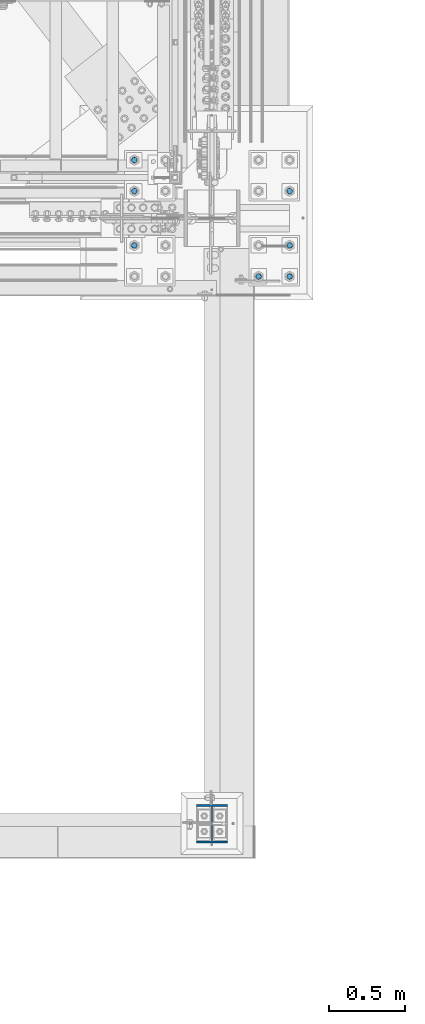
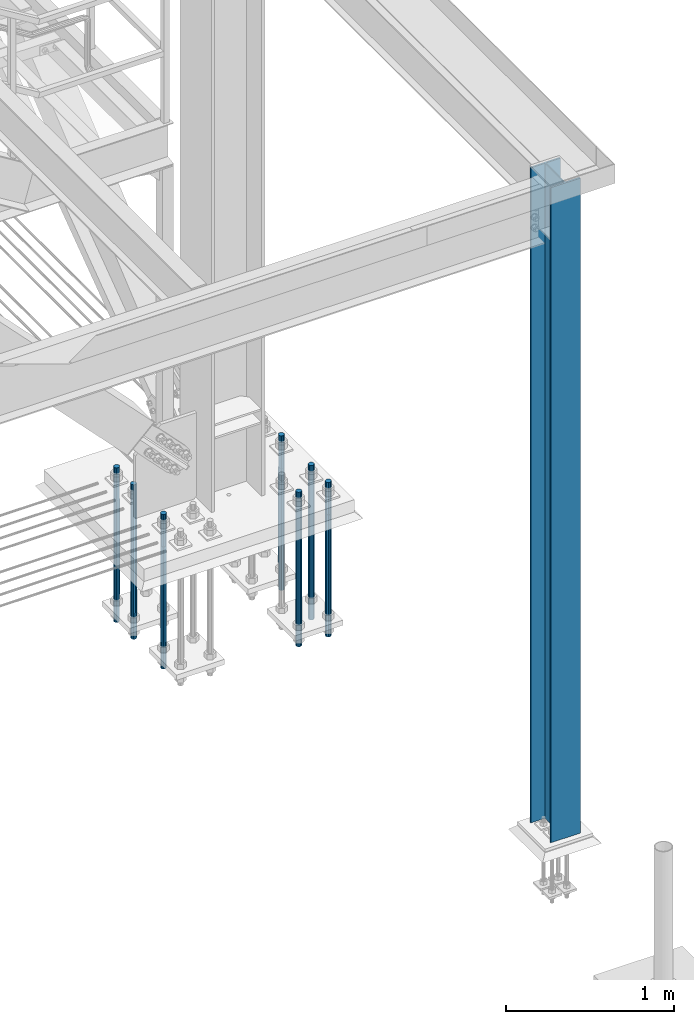
# One storey, part 1408 of 3843: 8 columns, 2 elements without a shape of their own.
"""IFC2X3 building model written with IfcOpenShell, lengths in millimetres."""

from ifc_helpers import new_model, si_unit, frame, origin_with_axes, place, context, subcontext, project, spatial, faceted_brep, material, type_object, element, aggregate, save


model = new_model("IFC2X3")

# Units and contexts
model_context = context("Model", 3, precision=1e-05, world=origin_with_axes())
body_context = subcontext(model_context, "Body", "Model", "MODEL_VIEW")
ifc_project = project(units=[si_unit("LENGTHUNIT", "METRE", prefix="MILLI"), si_unit("AREAUNIT", "SQUARE_METRE"), si_unit("VOLUMEUNIT", "CUBIC_METRE"), si_unit("MASSUNIT", "GRAM", prefix="KILO"), si_unit("TIMEUNIT", "SECOND"), si_unit("PLANEANGLEUNIT", "RADIAN"), si_unit("SOLIDANGLEUNIT", "STERADIAN"), si_unit("THERMODYNAMICTEMPERATUREUNIT", "DEGREE_CELSIUS"), si_unit("LUMINOUSINTENSITYUNIT", "LUMEN")], contexts=[model_context])

# Site, building, storey
site_placement = place(None, origin_with_axes())
site = spatial("IfcSite", under=ifc_project, at=site_placement, CompositionType="ELEMENT")
building_placement = place(site_placement, origin_with_axes())
building = spatial("IfcBuilding", under=site, at=building_placement, Name="Undefined", CompositionType="ELEMENT")
storey_placement = place(building_placement, origin_with_axes())
storey = spatial("IfcBuildingStorey", under=building, at=storey_placement, Name="Undefined", CompositionType="ELEMENT", Elevation=0.0)

# Assembly, column
assembly_1_placement = place(storey_placement, origin_with_axes())
assembly_1 = element("IfcElementAssembly", 1, at=assembly_1_placement, inside=storey, Name="COLUMN", AssemblyPlace="NOTDEFINED", PredefinedType="RIGID_FRAME")
ifc_material_1 = material(Name="STEEL/A992")
column_type_1 = type_object("IfcColumnType", Name="W10X39", PredefinedType="NOTDEFINED")
column_1_placement = place(assembly_1_placement, frame((85648.8, 11036.3, 30022.8), z_axis=(0.0, 1.0, 0.0), x_axis=(0.0, 0.0, 1.0)))
column_1 = element("IfcColumn", 2, at=column_1_placement, type_object=column_type_1, material=ifc_material_1, Name="COLUMN", ObjectType="W10X39", context=body_context, shape_type="Brep", body=[
    faceted_brep([(63.4999999999964, 101.600000000006, -125.4125), (63.4999999999964, 101.600000000006, -112.7125), (4826.00000000001, 101.600000000006, -112.7125), (4826.00000000001, 101.600000000006, -125.4125), (63.4999999999964, 3.96875, -112.7125), (4826.00000000001, 3.96875, -112.7125), (63.4999999999964, 3.96875, 112.7125), (4826.00000000001, 3.96875, 112.7125), (63.4999999999964, 101.600000000006, 112.7125), (4826.00000000001, 101.600000000006, 112.7125), (63.4999999999964, 101.600000000006, 125.4125), (4826.00000000001, 101.600000000006, 125.4125), (63.4999999999964, -101.600000000006, 125.4125), (4826.00000000001, -101.600000000006, 125.4125), (63.4999999999964, -101.600000000006, 112.7125), (4826.00000000001, -101.600000000006, 112.7125), (63.4999999999964, -3.96875, 112.7125), (4826.00000000001, -3.96875, 112.7125), (63.4999999999964, -3.96875, -112.7125), (4826.00000000001, -3.96875, -112.7125), (63.4999999999964, -101.600000000006, -112.7125), (4826.00000000001, -101.600000000006, -112.7125), (63.4999999999964, -101.600000000006, -125.4125), (4826.00000000001, -101.600000000006, -125.4125)], [[[0, 1, 2, 3]], [[1, 4, 5, 2]], [[4, 6, 7, 5]], [[6, 8, 9, 7]], [[8, 10, 11, 9]], [[10, 12, 13, 11]], [[12, 14, 15, 13]], [[14, 16, 17, 15]], [[16, 18, 19, 17]], [[18, 20, 21, 19]], [[20, 22, 23, 21]], [[22, 0, 3, 23]], [[5, 7, 9, 11, 13, 15, 17, 19, 21, 23, 3, 2]], [[22, 20, 18, 16, 14, 12, 10, 8, 6, 4, 1, 0]]]),
])
aggregate(assembly_1, [column_1])

# Assembly, columns
assembly_2_placement = place(storey_placement, origin_with_axes())
assembly_2 = element("IfcElementAssembly", 3, at=assembly_2_placement, inside=storey, Name="TEMPLATE", AssemblyPlace="NOTDEFINED", PredefinedType="RIGID_FRAME")
ifc_material_2 = material(Name="Undefined/F1554-GR.55")
column_type_2 = type_object("IfcColumnType", PredefinedType="NOTDEFINED")
column_2_placement = place(assembly_2_placement, frame((86156.8, 14617.7, 30022.8), z_axis=(1.0, 0.0, 0.0), x_axis=(0.0, 0.0, -1.0)))
column_2 = element("IfcColumn", 4, at=column_2_placement, type_object=column_type_2, material=ifc_material_2, Name="ANCHOR_ROD", context=body_context, shape_type="Brep", body=[
    faceted_brep([(-234.950000000001, -16.0214699700155, 9.25), (-234.950000000001, -9.25, 16.0214699700155), (-234.950000000001, 0.0, 18.5), (-234.950000000001, 9.25, 16.0214699700155), (-234.950000000001, 16.0214699700155, 9.25), (-234.950000000001, 18.5, 0.0), (-234.950000000001, 16.0214699700155, -9.25), (-234.950000000001, 9.25, -16.0214699700155), (-234.950000000001, 0.0, -18.5), (-234.950000000001, -9.25, -16.0214699700155), (-234.950000000001, -16.0214699700155, -9.25), (-234.950000000001, -18.5, 0.0), (0.0, 18.5, 0.0), (0.0, 16.0214699700118, -9.25), (0.0, 9.25, -16.0214699700155), (0.0, 0.0, -18.5), (0.0, -9.25, -16.0214699700155), (0.0, -16.0214699700118, -9.25), (0.0, -18.5, 0.0), (0.0, -16.0214699700118, 9.25), (0.0, -9.25, 16.0214699700155), (0.0, 0.0, 18.5), (0.0, 9.25, 16.0214699700155), (0.0, 16.0214699700118, 9.25), (0.0, -16.4977839420972, 9.52500000000146), (0.0, -9.52500000000146, 16.4977839420972), (0.0, 0.0, 19.0499989999989), (0.0, 9.52500000000146, 16.4977839420972), (0.0, 16.4977839420972, 9.52500000000146), (0.0, 19.0500000000029, 0.0), (0.0, 16.4977839420972, -9.52500000000146), (0.0, 9.52500000000146, -16.4977839420972), (0.0, 0.0, -19.0499989999989), (0.0, -9.52500000000146, -16.4977839420972), (0.0, -16.4977839420972, -9.52500000000146), (0.0, -19.0500000000029, 0.0), (698.5, -19.0499999999993, 0.0), (698.5, -16.4977839420935, 9.52499999999418), (698.5, -9.52500000000146, 16.4977839420899), (698.5, 0.0, 19.0500000000029), (698.5, 9.52500000000146, 16.4977839420899), (698.5, 16.4977839420935, 9.52499999999418), (698.5, 19.0499999999993, 0.0), (698.5, 16.4977839420935, -9.52499999999418), (698.5, 9.52500000000146, -16.4977839420899), (698.5, 0.0, -19.0500000000029), (698.5, -9.52500000000146, -16.4977839420899), (698.5, -16.4977839420935, -9.52499999999418), (698.5, -9.25, 16.0214699700155), (698.5, 0.0, 18.5), (698.5, 9.25, 16.0214699700155), (698.5, 16.0214699700118, 9.25), (698.5, 18.5, 0.0), (698.5, 16.0214699700118, -9.25), (698.5, 9.25, -16.0214699700155), (698.5, 0.0, -18.5), (698.5, -9.25, -16.0214699700155), (698.5, -16.0214699700118, -9.25), (698.5, -18.5, 0.0), (698.5, -16.0214699700118, 9.25), (889.0, -9.25, -16.0214699700155), (889.0, 0.0, -18.5), (889.0, 9.25, -16.0214699700155), (889.0, 16.0214699700118, -9.25), (889.0, 18.5, 0.0), (889.0, 16.0214699700118, 9.25), (889.0, 9.25, 16.0214699700155), (889.0, 0.0, 18.5), (889.0, -9.25, 16.0214699700155), (889.0, -16.0214699700118, 9.25), (889.0, -18.5, 0.0), (889.0, -16.0214699700118, -9.25)], [[[0, 1, 2, 3, 4, 5, 6, 7, 8, 9, 10, 11]], [[6, 5, 12, 13]], [[7, 6, 13, 14]], [[8, 7, 14, 15]], [[9, 8, 15, 16]], [[10, 9, 16, 17]], [[11, 10, 17, 18]], [[0, 11, 18, 19]], [[1, 0, 19, 20]], [[2, 1, 20, 21]], [[3, 2, 21, 22]], [[4, 3, 22, 23]], [[5, 4, 23, 12]], [[24, 25, 26, 27, 28, 29, 30, 31, 32, 33, 34, 35], [22, 21, 20, 19, 18, 17, 16, 15, 14, 13, 12, 23]], [[24, 35, 36, 37]], [[25, 24, 37, 38]], [[26, 25, 38, 39]], [[27, 26, 39, 40]], [[28, 27, 40, 41]], [[29, 28, 41, 42]], [[30, 29, 42, 43]], [[31, 30, 43, 44]], [[32, 31, 44, 45]], [[33, 32, 45, 46]], [[34, 33, 46, 47]], [[35, 34, 47, 36]], [[46, 45, 44, 43, 42, 41, 40, 39, 38, 37, 36, 47], [48, 49, 50, 51, 52, 53, 54, 55, 56, 57, 58, 59]], [[60, 61, 62, 63, 64, 65, 66, 67, 68, 69, 70, 71]], [[68, 67, 49, 48]], [[69, 68, 48, 59]], [[70, 69, 59, 58]], [[71, 70, 58, 57]], [[60, 71, 57, 56]], [[61, 60, 56, 55]], [[62, 61, 55, 54]], [[63, 62, 54, 53]], [[64, 63, 53, 52]], [[65, 64, 52, 51]], [[66, 65, 51, 50]], [[67, 66, 50, 49]]]),
])
column_3_placement = place(assembly_2_placement, frame((86156.8, 14820.9, 30022.8), z_axis=(1.0, 0.0, 0.0), x_axis=(0.0, 0.0, -1.0)))
column_3 = element("IfcColumn", 5, at=column_3_placement, type_object=column_type_2, material=ifc_material_2, Name="ANCHOR_ROD", context=body_context, shape_type="Brep", body=[
    faceted_brep([(-234.950000000001, -16.0214699700155, 9.25), (-234.950000000001, -9.25, 16.0214699700155), (-234.950000000001, 0.0, 18.5), (-234.950000000001, 9.25, 16.0214699700155), (-234.950000000001, 16.0214699700155, 9.25), (-234.950000000001, 18.5, 0.0), (-234.950000000001, 16.0214699700155, -9.25), (-234.950000000001, 9.25, -16.0214699700155), (-234.950000000001, 0.0, -18.5), (-234.950000000001, -9.25, -16.0214699700155), (-234.950000000001, -16.0214699700155, -9.25), (-234.950000000001, -18.5, 0.0), (0.0, 18.5, 0.0), (0.0, 16.0214699700118, -9.25), (0.0, 9.25, -16.0214699700155), (0.0, 0.0, -18.5), (0.0, -9.25, -16.0214699700155), (0.0, -16.0214699700118, -9.25), (0.0, -18.5, 0.0), (0.0, -16.0214699700118, 9.25), (0.0, -9.25, 16.0214699700155), (0.0, 0.0, 18.5), (0.0, 9.25, 16.0214699700155), (0.0, 16.0214699700118, 9.25), (0.0, -16.4977839420972, 9.52500000000146), (0.0, -9.52500000000146, 16.4977839420972), (0.0, 0.0, 19.0499989999989), (0.0, 9.52500000000146, 16.4977839420972), (0.0, 16.4977839420972, 9.52500000000146), (0.0, 19.0500000000029, 0.0), (0.0, 16.4977839420972, -9.52500000000146), (0.0, 9.52500000000146, -16.4977839420972), (0.0, 0.0, -19.0499989999989), (0.0, -9.52500000000146, -16.4977839420972), (0.0, -16.4977839420972, -9.52500000000146), (0.0, -19.0500000000029, 0.0), (698.5, -19.0499999999993, 0.0), (698.5, -16.4977839420935, 9.52499999999418), (698.5, -9.52500000000146, 16.4977839420899), (698.5, 0.0, 19.0500000000029), (698.5, 9.52500000000146, 16.4977839420899), (698.5, 16.4977839420935, 9.52499999999418), (698.5, 19.0499999999993, 0.0), (698.5, 16.4977839420935, -9.52499999999418), (698.5, 9.52500000000146, -16.4977839420899), (698.5, 0.0, -19.0500000000029), (698.5, -9.52500000000146, -16.4977839420899), (698.5, -16.4977839420935, -9.52499999999418), (698.5, -9.25, 16.0214699700155), (698.5, 0.0, 18.5), (698.5, 9.25, 16.0214699700155), (698.5, 16.0214699700118, 9.25), (698.5, 18.5, 0.0), (698.5, 16.0214699700118, -9.25), (698.5, 9.25, -16.0214699700155), (698.5, 0.0, -18.5), (698.5, -9.25, -16.0214699700155), (698.5, -16.0214699700118, -9.25), (698.5, -18.5, 0.0), (698.5, -16.0214699700118, 9.25), (889.0, -9.25, -16.0214699700155), (889.0, 0.0, -18.5), (889.0, 9.25, -16.0214699700155), (889.0, 16.0214699700118, -9.25), (889.0, 18.5, 0.0), (889.0, 16.0214699700118, 9.25), (889.0, 9.25, 16.0214699700155), (889.0, 0.0, 18.5), (889.0, -9.25, 16.0214699700155), (889.0, -16.0214699700118, 9.25), (889.0, -18.5, 0.0), (889.0, -16.0214699700118, -9.25)], [[[0, 1, 2, 3, 4, 5, 6, 7, 8, 9, 10, 11]], [[6, 5, 12, 13]], [[7, 6, 13, 14]], [[8, 7, 14, 15]], [[9, 8, 15, 16]], [[10, 9, 16, 17]], [[11, 10, 17, 18]], [[0, 11, 18, 19]], [[1, 0, 19, 20]], [[2, 1, 20, 21]], [[3, 2, 21, 22]], [[4, 3, 22, 23]], [[5, 4, 23, 12]], [[24, 25, 26, 27, 28, 29, 30, 31, 32, 33, 34, 35], [22, 21, 20, 19, 18, 17, 16, 15, 14, 13, 12, 23]], [[24, 35, 36, 37]], [[25, 24, 37, 38]], [[26, 25, 38, 39]], [[27, 26, 39, 40]], [[28, 27, 40, 41]], [[29, 28, 41, 42]], [[30, 29, 42, 43]], [[31, 30, 43, 44]], [[32, 31, 44, 45]], [[33, 32, 45, 46]], [[34, 33, 46, 47]], [[35, 34, 47, 36]], [[46, 45, 44, 43, 42, 41, 40, 39, 38, 37, 36, 47], [48, 49, 50, 51, 52, 53, 54, 55, 56, 57, 58, 59]], [[60, 61, 62, 63, 64, 65, 66, 67, 68, 69, 70, 71]], [[68, 67, 49, 48]], [[69, 68, 48, 59]], [[70, 69, 59, 58]], [[71, 70, 58, 57]], [[60, 71, 57, 56]], [[61, 60, 56, 55]], [[62, 61, 55, 54]], [[63, 62, 54, 53]], [[64, 63, 53, 52]], [[65, 64, 52, 51]], [[66, 65, 51, 50]], [[67, 66, 50, 49]]]),
])
column_4_placement = place(assembly_2_placement, frame((86156.8, 15176.5, 30022.8), z_axis=(-1.0, 0.0, 0.0), x_axis=(0.0, 0.0, -1.0)))
column_4 = element("IfcColumn", 6, at=column_4_placement, type_object=column_type_2, material=ifc_material_2, Name="ANCHOR_ROD", context=body_context, shape_type="Brep", body=[
    faceted_brep([(-234.950000000001, -16.0214699700155, 9.25), (-234.950000000001, -9.25, 16.0214699700155), (-234.950000000001, 0.0, 18.5), (-234.950000000001, 9.25, 16.0214699700155), (-234.950000000001, 16.0214699700155, 9.25), (-234.950000000001, 18.5, 0.0), (-234.950000000001, 16.0214699700155, -9.25), (-234.950000000001, 9.25, -16.0214699700155), (-234.950000000001, 0.0, -18.5), (-234.950000000001, -9.25, -16.0214699700155), (-234.950000000001, -16.0214699700155, -9.25), (-234.950000000001, -18.5, 0.0), (0.0, 18.5, 0.0), (0.0, 16.0214699700118, -9.25), (0.0, 9.25, -16.0214699700155), (0.0, 0.0, -18.5), (0.0, -9.25, -16.0214699700155), (0.0, -16.0214699700118, -9.25), (0.0, -18.5, 0.0), (0.0, -16.0214699700118, 9.25), (0.0, -9.25, 16.0214699700155), (0.0, 0.0, 18.5), (0.0, 9.25, 16.0214699700155), (0.0, 16.0214699700118, 9.25), (0.0, -16.4977839420972, 9.52500000000146), (0.0, -9.52500000000146, 16.4977839420972), (0.0, 0.0, 19.0499989999989), (0.0, 9.52500000000146, 16.4977839420972), (0.0, 16.4977839420972, 9.52500000000146), (0.0, 19.0500000000029, 0.0), (0.0, 16.4977839420972, -9.52500000000146), (0.0, 9.52500000000146, -16.4977839420972), (0.0, 0.0, -19.0499989999989), (0.0, -9.52500000000146, -16.4977839420972), (0.0, -16.4977839420972, -9.52500000000146), (0.0, -19.0500000000029, 0.0), (698.5, -19.0499999999993, 0.0), (698.5, -16.4977839420935, 9.52499999999418), (698.5, -9.52500000000146, 16.4977839420899), (698.5, 0.0, 19.0500000000029), (698.5, 9.52500000000146, 16.4977839420899), (698.5, 16.4977839420935, 9.52499999999418), (698.5, 19.0499999999993, 0.0), (698.5, 16.4977839420935, -9.52499999999418), (698.5, 9.52500000000146, -16.4977839420899), (698.5, 0.0, -19.0500000000029), (698.5, -9.52500000000146, -16.4977839420899), (698.5, -16.4977839420935, -9.52499999999418), (698.5, -9.25, 16.0214699700155), (698.5, 0.0, 18.5), (698.5, 9.25, 16.0214699700155), (698.5, 16.0214699700118, 9.25), (698.5, 18.5, 0.0), (698.5, 16.0214699700118, -9.25), (698.5, 9.25, -16.0214699700155), (698.5, 0.0, -18.5), (698.5, -9.25, -16.0214699700155), (698.5, -16.0214699700118, -9.25), (698.5, -18.5, 0.0), (698.5, -16.0214699700118, 9.25), (889.0, -9.25, -16.0214699700155), (889.0, 0.0, -18.5), (889.0, 9.25, -16.0214699700155), (889.0, 16.0214699700118, -9.25), (889.0, 18.5, 0.0), (889.0, 16.0214699700118, 9.25), (889.0, 9.25, 16.0214699700155), (889.0, 0.0, 18.5), (889.0, -9.25, 16.0214699700155), (889.0, -16.0214699700118, 9.25), (889.0, -18.5, 0.0), (889.0, -16.0214699700118, -9.25)], [[[0, 1, 2, 3, 4, 5, 6, 7, 8, 9, 10, 11]], [[6, 5, 12, 13]], [[7, 6, 13, 14]], [[8, 7, 14, 15]], [[9, 8, 15, 16]], [[10, 9, 16, 17]], [[11, 10, 17, 18]], [[0, 11, 18, 19]], [[1, 0, 19, 20]], [[2, 1, 20, 21]], [[3, 2, 21, 22]], [[4, 3, 22, 23]], [[5, 4, 23, 12]], [[24, 25, 26, 27, 28, 29, 30, 31, 32, 33, 34, 35], [22, 21, 20, 19, 18, 17, 16, 15, 14, 13, 12, 23]], [[24, 35, 36, 37]], [[25, 24, 37, 38]], [[26, 25, 38, 39]], [[27, 26, 39, 40]], [[28, 27, 40, 41]], [[29, 28, 41, 42]], [[30, 29, 42, 43]], [[31, 30, 43, 44]], [[32, 31, 44, 45]], [[33, 32, 45, 46]], [[34, 33, 46, 47]], [[35, 34, 47, 36]], [[46, 45, 44, 43, 42, 41, 40, 39, 38, 37, 36, 47], [48, 49, 50, 51, 52, 53, 54, 55, 56, 57, 58, 59]], [[60, 61, 62, 63, 64, 65, 66, 67, 68, 69, 70, 71]], [[68, 67, 49, 48]], [[69, 68, 48, 59]], [[70, 69, 59, 58]], [[71, 70, 58, 57]], [[60, 71, 57, 56]], [[61, 60, 56, 55]], [[62, 61, 55, 54]], [[63, 62, 54, 53]], [[64, 63, 53, 52]], [[65, 64, 52, 51]], [[66, 65, 51, 50]], [[67, 66, 50, 49]]]),
])
column_5_placement = place(assembly_2_placement, frame((85953.6, 14617.7, 30022.8), z_axis=(1.0, 0.0, 0.0), x_axis=(0.0, 0.0, -1.0)))
column_5 = element("IfcColumn", 7, at=column_5_placement, type_object=column_type_2, material=ifc_material_2, Name="ANCHOR_ROD", context=body_context, shape_type="Brep", body=[
    faceted_brep([(-234.950000000001, -16.0214699700155, 9.25), (-234.950000000001, -9.25, 16.0214699700155), (-234.950000000001, 0.0, 18.5), (-234.950000000001, 9.25, 16.0214699700155), (-234.950000000001, 16.0214699700155, 9.25), (-234.950000000001, 18.5, 0.0), (-234.950000000001, 16.0214699700155, -9.25), (-234.950000000001, 9.25, -16.0214699700155), (-234.950000000001, 0.0, -18.5), (-234.950000000001, -9.25, -16.0214699700155), (-234.950000000001, -16.0214699700155, -9.25), (-234.950000000001, -18.5, 0.0), (0.0, 18.5, 0.0), (0.0, 16.0214699700118, -9.25), (0.0, 9.25, -16.0214699700155), (0.0, 0.0, -18.5), (0.0, -9.25, -16.0214699700155), (0.0, -16.0214699700118, -9.25), (0.0, -18.5, 0.0), (0.0, -16.0214699700118, 9.25), (0.0, -9.25, 16.0214699700155), (0.0, 0.0, 18.5), (0.0, 9.25, 16.0214699700155), (0.0, 16.0214699700118, 9.25), (0.0, -16.4977839420972, 9.52500000000146), (0.0, -9.52500000000146, 16.4977839420972), (0.0, 0.0, 19.0499989999989), (0.0, 9.52500000000146, 16.4977839420972), (0.0, 16.4977839420972, 9.52500000000146), (0.0, 19.0500000000029, 0.0), (0.0, 16.4977839420972, -9.52500000000146), (0.0, 9.52500000000146, -16.4977839420972), (0.0, 0.0, -19.0499989999989), (0.0, -9.52500000000146, -16.4977839420972), (0.0, -16.4977839420972, -9.52500000000146), (0.0, -19.0500000000029, 0.0), (698.5, -19.0499999999993, 0.0), (698.5, -16.4977839420935, 9.52499999999418), (698.5, -9.52500000000146, 16.4977839420899), (698.5, 0.0, 19.0500000000029), (698.5, 9.52500000000146, 16.4977839420899), (698.5, 16.4977839420935, 9.52499999999418), (698.5, 19.0499999999993, 0.0), (698.5, 16.4977839420935, -9.52499999999418), (698.5, 9.52500000000146, -16.4977839420899), (698.5, 0.0, -19.0500000000029), (698.5, -9.52500000000146, -16.4977839420899), (698.5, -16.4977839420935, -9.52499999999418), (698.5, -9.25, 16.0214699700155), (698.5, 0.0, 18.5), (698.5, 9.25, 16.0214699700155), (698.5, 16.0214699700118, 9.25), (698.5, 18.5, 0.0), (698.5, 16.0214699700118, -9.25), (698.5, 9.25, -16.0214699700155), (698.5, 0.0, -18.5), (698.5, -9.25, -16.0214699700155), (698.5, -16.0214699700118, -9.25), (698.5, -18.5, 0.0), (698.5, -16.0214699700118, 9.25), (889.0, -9.25, -16.0214699700155), (889.0, 0.0, -18.5), (889.0, 9.25, -16.0214699700155), (889.0, 16.0214699700118, -9.25), (889.0, 18.5, 0.0), (889.0, 16.0214699700118, 9.25), (889.0, 9.25, 16.0214699700155), (889.0, 0.0, 18.5), (889.0, -9.25, 16.0214699700155), (889.0, -16.0214699700118, 9.25), (889.0, -18.5, 0.0), (889.0, -16.0214699700118, -9.25)], [[[0, 1, 2, 3, 4, 5, 6, 7, 8, 9, 10, 11]], [[6, 5, 12, 13]], [[7, 6, 13, 14]], [[8, 7, 14, 15]], [[9, 8, 15, 16]], [[10, 9, 16, 17]], [[11, 10, 17, 18]], [[0, 11, 18, 19]], [[1, 0, 19, 20]], [[2, 1, 20, 21]], [[3, 2, 21, 22]], [[4, 3, 22, 23]], [[5, 4, 23, 12]], [[24, 25, 26, 27, 28, 29, 30, 31, 32, 33, 34, 35], [22, 21, 20, 19, 18, 17, 16, 15, 14, 13, 12, 23]], [[24, 35, 36, 37]], [[25, 24, 37, 38]], [[26, 25, 38, 39]], [[27, 26, 39, 40]], [[28, 27, 40, 41]], [[29, 28, 41, 42]], [[30, 29, 42, 43]], [[31, 30, 43, 44]], [[32, 31, 44, 45]], [[33, 32, 45, 46]], [[34, 33, 46, 47]], [[35, 34, 47, 36]], [[46, 45, 44, 43, 42, 41, 40, 39, 38, 37, 36, 47], [48, 49, 50, 51, 52, 53, 54, 55, 56, 57, 58, 59]], [[60, 61, 62, 63, 64, 65, 66, 67, 68, 69, 70, 71]], [[68, 67, 49, 48]], [[69, 68, 48, 59]], [[70, 69, 59, 58]], [[71, 70, 58, 57]], [[60, 71, 57, 56]], [[61, 60, 56, 55]], [[62, 61, 55, 54]], [[63, 62, 54, 53]], [[64, 63, 53, 52]], [[65, 64, 52, 51]], [[66, 65, 51, 50]], [[67, 66, 50, 49]]]),
])
column_6_placement = place(assembly_2_placement, frame((85140.8, 14820.9, 30022.8), z_axis=(1.0, 0.0, 0.0), x_axis=(0.0, 0.0, -1.0)))
column_6 = element("IfcColumn", 8, at=column_6_placement, type_object=column_type_2, material=ifc_material_2, Name="ANCHOR_ROD", context=body_context, shape_type="Brep", body=[
    faceted_brep([(-234.950000000001, -16.0214699700155, 9.25), (-234.950000000001, -9.25, 16.0214699700155), (-234.950000000001, 0.0, 18.5), (-234.950000000001, 9.25, 16.0214699700155), (-234.950000000001, 16.0214699700155, 9.25), (-234.950000000001, 18.5, 0.0), (-234.950000000001, 16.0214699700155, -9.25), (-234.950000000001, 9.25, -16.0214699700155), (-234.950000000001, 0.0, -18.5), (-234.950000000001, -9.25, -16.0214699700155), (-234.950000000001, -16.0214699700155, -9.25), (-234.950000000001, -18.5, 0.0), (0.0, 18.5, 0.0), (0.0, 16.0214699700118, -9.25), (0.0, 9.25, -16.0214699700155), (0.0, 0.0, -18.5), (0.0, -9.25, -16.0214699700155), (0.0, -16.0214699700118, -9.25), (0.0, -18.5, 0.0), (0.0, -16.0214699700118, 9.25), (0.0, -9.25, 16.0214699700155), (0.0, 0.0, 18.5), (0.0, 9.25, 16.0214699700155), (0.0, 16.0214699700118, 9.25), (0.0, -16.4977839420972, 9.52500000000146), (0.0, -9.52500000000146, 16.4977839420972), (0.0, 0.0, 19.0499989999989), (0.0, 9.52500000000146, 16.4977839420972), (0.0, 16.4977839420972, 9.52500000000146), (0.0, 19.0500000000029, 0.0), (0.0, 16.4977839420972, -9.52500000000146), (0.0, 9.52500000000146, -16.4977839420972), (0.0, 0.0, -19.0499989999989), (0.0, -9.52500000000146, -16.4977839420972), (0.0, -16.4977839420972, -9.52500000000146), (0.0, -19.0500000000029, 0.0), (698.5, -19.0499999999993, 0.0), (698.5, -16.4977839420935, 9.52499999999418), (698.5, -9.52500000000146, 16.4977839420899), (698.5, 0.0, 19.0500000000029), (698.5, 9.52500000000146, 16.4977839420899), (698.5, 16.4977839420935, 9.52499999999418), (698.5, 19.0499999999993, 0.0), (698.5, 16.4977839420935, -9.52499999999418), (698.5, 9.52500000000146, -16.4977839420899), (698.5, 0.0, -19.0500000000029), (698.5, -9.52500000000146, -16.4977839420899), (698.5, -16.4977839420935, -9.52499999999418), (698.5, -9.25, 16.0214699700155), (698.5, 0.0, 18.5), (698.5, 9.25, 16.0214699700155), (698.5, 16.0214699700118, 9.25), (698.5, 18.5, 0.0), (698.5, 16.0214699700118, -9.25), (698.5, 9.25, -16.0214699700155), (698.5, 0.0, -18.5), (698.5, -9.25, -16.0214699700155), (698.5, -16.0214699700118, -9.25), (698.5, -18.5, 0.0), (698.5, -16.0214699700118, 9.25), (889.0, -9.25, -16.0214699700155), (889.0, 0.0, -18.5), (889.0, 9.25, -16.0214699700155), (889.0, 16.0214699700118, -9.25), (889.0, 18.5, 0.0), (889.0, 16.0214699700118, 9.25), (889.0, 9.25, 16.0214699700155), (889.0, 0.0, 18.5), (889.0, -9.25, 16.0214699700155), (889.0, -16.0214699700118, 9.25), (889.0, -18.5, 0.0), (889.0, -16.0214699700118, -9.25)], [[[0, 1, 2, 3, 4, 5, 6, 7, 8, 9, 10, 11]], [[6, 5, 12, 13]], [[7, 6, 13, 14]], [[8, 7, 14, 15]], [[9, 8, 15, 16]], [[10, 9, 16, 17]], [[11, 10, 17, 18]], [[0, 11, 18, 19]], [[1, 0, 19, 20]], [[2, 1, 20, 21]], [[3, 2, 21, 22]], [[4, 3, 22, 23]], [[5, 4, 23, 12]], [[24, 25, 26, 27, 28, 29, 30, 31, 32, 33, 34, 35], [22, 21, 20, 19, 18, 17, 16, 15, 14, 13, 12, 23]], [[24, 35, 36, 37]], [[25, 24, 37, 38]], [[26, 25, 38, 39]], [[27, 26, 39, 40]], [[28, 27, 40, 41]], [[29, 28, 41, 42]], [[30, 29, 42, 43]], [[31, 30, 43, 44]], [[32, 31, 44, 45]], [[33, 32, 45, 46]], [[34, 33, 46, 47]], [[35, 34, 47, 36]], [[46, 45, 44, 43, 42, 41, 40, 39, 38, 37, 36, 47], [48, 49, 50, 51, 52, 53, 54, 55, 56, 57, 58, 59]], [[60, 61, 62, 63, 64, 65, 66, 67, 68, 69, 70, 71]], [[68, 67, 49, 48]], [[69, 68, 48, 59]], [[70, 69, 59, 58]], [[71, 70, 58, 57]], [[60, 71, 57, 56]], [[61, 60, 56, 55]], [[62, 61, 55, 54]], [[63, 62, 54, 53]], [[64, 63, 53, 52]], [[65, 64, 52, 51]], [[66, 65, 51, 50]], [[67, 66, 50, 49]]]),
])
column_7_placement = place(assembly_2_placement, frame((85140.8, 15176.5, 30022.8), z_axis=(-1.0, 0.0, 0.0), x_axis=(0.0, 0.0, -1.0)))
column_7 = element("IfcColumn", 9, at=column_7_placement, type_object=column_type_2, material=ifc_material_2, Name="ANCHOR_ROD", context=body_context, shape_type="Brep", body=[
    faceted_brep([(-234.950000000001, -16.0214699700155, 9.25), (-234.950000000001, -9.25, 16.0214699700155), (-234.950000000001, 0.0, 18.5), (-234.950000000001, 9.25, 16.0214699700155), (-234.950000000001, 16.0214699700155, 9.25), (-234.950000000001, 18.5, 0.0), (-234.950000000001, 16.0214699700155, -9.25), (-234.950000000001, 9.25, -16.0214699700155), (-234.950000000001, 0.0, -18.5), (-234.950000000001, -9.25, -16.0214699700155), (-234.950000000001, -16.0214699700155, -9.25), (-234.950000000001, -18.5, 0.0), (0.0, 18.5, 0.0), (0.0, 16.0214699700118, -9.25), (0.0, 9.25, -16.0214699700155), (0.0, 0.0, -18.5), (0.0, -9.25, -16.0214699700155), (0.0, -16.0214699700118, -9.25), (0.0, -18.5, 0.0), (0.0, -16.0214699700118, 9.25), (0.0, -9.25, 16.0214699700155), (0.0, 0.0, 18.5), (0.0, 9.25, 16.0214699700155), (0.0, 16.0214699700118, 9.25), (0.0, -16.4977839420972, 9.52500000000146), (0.0, -9.52500000000146, 16.4977839420972), (0.0, 0.0, 19.0499989999989), (0.0, 9.52500000000146, 16.4977839420972), (0.0, 16.4977839420972, 9.52500000000146), (0.0, 19.0500000000029, 0.0), (0.0, 16.4977839420972, -9.52500000000146), (0.0, 9.52500000000146, -16.4977839420972), (0.0, 0.0, -19.0499989999989), (0.0, -9.52500000000146, -16.4977839420972), (0.0, -16.4977839420972, -9.52500000000146), (0.0, -19.0500000000029, 0.0), (698.5, -19.0499999999993, 0.0), (698.5, -16.4977839420935, 9.52499999999418), (698.5, -9.52500000000146, 16.4977839420899), (698.5, 0.0, 19.0500000000029), (698.5, 9.52500000000146, 16.4977839420899), (698.5, 16.4977839420935, 9.52499999999418), (698.5, 19.0499999999993, 0.0), (698.5, 16.4977839420935, -9.52499999999418), (698.5, 9.52500000000146, -16.4977839420899), (698.5, 0.0, -19.0500000000029), (698.5, -9.52500000000146, -16.4977839420899), (698.5, -16.4977839420935, -9.52499999999418), (698.5, -9.25, 16.0214699700155), (698.5, 0.0, 18.5), (698.5, 9.25, 16.0214699700155), (698.5, 16.0214699700118, 9.25), (698.5, 18.5, 0.0), (698.5, 16.0214699700118, -9.25), (698.5, 9.25, -16.0214699700155), (698.5, 0.0, -18.5), (698.5, -9.25, -16.0214699700155), (698.5, -16.0214699700118, -9.25), (698.5, -18.5, 0.0), (698.5, -16.0214699700118, 9.25), (889.0, -9.25, -16.0214699700155), (889.0, 0.0, -18.5), (889.0, 9.25, -16.0214699700155), (889.0, 16.0214699700118, -9.25), (889.0, 18.5, 0.0), (889.0, 16.0214699700118, 9.25), (889.0, 9.25, 16.0214699700155), (889.0, 0.0, 18.5), (889.0, -9.25, 16.0214699700155), (889.0, -16.0214699700118, 9.25), (889.0, -18.5, 0.0), (889.0, -16.0214699700118, -9.25)], [[[0, 1, 2, 3, 4, 5, 6, 7, 8, 9, 10, 11]], [[6, 5, 12, 13]], [[7, 6, 13, 14]], [[8, 7, 14, 15]], [[9, 8, 15, 16]], [[10, 9, 16, 17]], [[11, 10, 17, 18]], [[0, 11, 18, 19]], [[1, 0, 19, 20]], [[2, 1, 20, 21]], [[3, 2, 21, 22]], [[4, 3, 22, 23]], [[5, 4, 23, 12]], [[24, 25, 26, 27, 28, 29, 30, 31, 32, 33, 34, 35], [22, 21, 20, 19, 18, 17, 16, 15, 14, 13, 12, 23]], [[24, 35, 36, 37]], [[25, 24, 37, 38]], [[26, 25, 38, 39]], [[27, 26, 39, 40]], [[28, 27, 40, 41]], [[29, 28, 41, 42]], [[30, 29, 42, 43]], [[31, 30, 43, 44]], [[32, 31, 44, 45]], [[33, 32, 45, 46]], [[34, 33, 46, 47]], [[35, 34, 47, 36]], [[46, 45, 44, 43, 42, 41, 40, 39, 38, 37, 36, 47], [48, 49, 50, 51, 52, 53, 54, 55, 56, 57, 58, 59]], [[60, 61, 62, 63, 64, 65, 66, 67, 68, 69, 70, 71]], [[68, 67, 49, 48]], [[69, 68, 48, 59]], [[70, 69, 59, 58]], [[71, 70, 58, 57]], [[60, 71, 57, 56]], [[61, 60, 56, 55]], [[62, 61, 55, 54]], [[63, 62, 54, 53]], [[64, 63, 53, 52]], [[65, 64, 52, 51]], [[66, 65, 51, 50]], [[67, 66, 50, 49]]]),
])
column_8_placement = place(assembly_2_placement, frame((85140.8, 15379.7, 30022.8), z_axis=(-1.0, 0.0, 0.0), x_axis=(0.0, 0.0, -1.0)))
column_8 = element("IfcColumn", 10, at=column_8_placement, type_object=column_type_2, material=ifc_material_2, Name="ANCHOR_ROD", context=body_context, shape_type="Brep", body=[
    faceted_brep([(-234.950000000001, -16.0214699700155, 9.25), (-234.950000000001, -9.25, 16.0214699700155), (-234.950000000001, 0.0, 18.5), (-234.950000000001, 9.25, 16.0214699700155), (-234.950000000001, 16.0214699700155, 9.25), (-234.950000000001, 18.5, 0.0), (-234.950000000001, 16.0214699700155, -9.25), (-234.950000000001, 9.25, -16.0214699700155), (-234.950000000001, 0.0, -18.5), (-234.950000000001, -9.25, -16.0214699700155), (-234.950000000001, -16.0214699700155, -9.25), (-234.950000000001, -18.5, 0.0), (0.0, 18.5, 0.0), (0.0, 16.0214699700118, -9.25), (0.0, 9.25, -16.0214699700155), (0.0, 0.0, -18.5), (0.0, -9.25, -16.0214699700155), (0.0, -16.0214699700118, -9.25), (0.0, -18.5, 0.0), (0.0, -16.0214699700118, 9.25), (0.0, -9.25, 16.0214699700155), (0.0, 0.0, 18.5), (0.0, 9.25, 16.0214699700155), (0.0, 16.0214699700118, 9.25), (0.0, -16.4977839420972, 9.52500000000146), (0.0, -9.52500000000146, 16.4977839420972), (0.0, 0.0, 19.0499989999989), (0.0, 9.52500000000146, 16.4977839420972), (0.0, 16.4977839420972, 9.52500000000146), (0.0, 19.0500000000029, 0.0), (0.0, 16.4977839420972, -9.52500000000146), (0.0, 9.52500000000146, -16.4977839420972), (0.0, 0.0, -19.0499989999989), (0.0, -9.52500000000146, -16.4977839420972), (0.0, -16.4977839420972, -9.52500000000146), (0.0, -19.0500000000029, 0.0), (698.5, -19.0499999999993, 0.0), (698.5, -16.4977839420935, 9.52499999999418), (698.5, -9.52500000000146, 16.4977839420899), (698.5, 0.0, 19.0500000000029), (698.5, 9.52500000000146, 16.4977839420899), (698.5, 16.4977839420935, 9.52499999999418), (698.5, 19.0499999999993, 0.0), (698.5, 16.4977839420935, -9.52499999999418), (698.5, 9.52500000000146, -16.4977839420899), (698.5, 0.0, -19.0500000000029), (698.5, -9.52500000000146, -16.4977839420899), (698.5, -16.4977839420935, -9.52499999999418), (698.5, -9.25, 16.0214699700155), (698.5, 0.0, 18.5), (698.5, 9.25, 16.0214699700155), (698.5, 16.0214699700118, 9.25), (698.5, 18.5, 0.0), (698.5, 16.0214699700118, -9.25), (698.5, 9.25, -16.0214699700155), (698.5, 0.0, -18.5), (698.5, -9.25, -16.0214699700155), (698.5, -16.0214699700118, -9.25), (698.5, -18.5, 0.0), (698.5, -16.0214699700118, 9.25), (889.0, -9.25, -16.0214699700155), (889.0, 0.0, -18.5), (889.0, 9.25, -16.0214699700155), (889.0, 16.0214699700118, -9.25), (889.0, 18.5, 0.0), (889.0, 16.0214699700118, 9.25), (889.0, 9.25, 16.0214699700155), (889.0, 0.0, 18.5), (889.0, -9.25, 16.0214699700155), (889.0, -16.0214699700118, 9.25), (889.0, -18.5, 0.0), (889.0, -16.0214699700118, -9.25)], [[[0, 1, 2, 3, 4, 5, 6, 7, 8, 9, 10, 11]], [[6, 5, 12, 13]], [[7, 6, 13, 14]], [[8, 7, 14, 15]], [[9, 8, 15, 16]], [[10, 9, 16, 17]], [[11, 10, 17, 18]], [[0, 11, 18, 19]], [[1, 0, 19, 20]], [[2, 1, 20, 21]], [[3, 2, 21, 22]], [[4, 3, 22, 23]], [[5, 4, 23, 12]], [[24, 25, 26, 27, 28, 29, 30, 31, 32, 33, 34, 35], [22, 21, 20, 19, 18, 17, 16, 15, 14, 13, 12, 23]], [[24, 35, 36, 37]], [[25, 24, 37, 38]], [[26, 25, 38, 39]], [[27, 26, 39, 40]], [[28, 27, 40, 41]], [[29, 28, 41, 42]], [[30, 29, 42, 43]], [[31, 30, 43, 44]], [[32, 31, 44, 45]], [[33, 32, 45, 46]], [[34, 33, 46, 47]], [[35, 34, 47, 36]], [[46, 45, 44, 43, 42, 41, 40, 39, 38, 37, 36, 47], [48, 49, 50, 51, 52, 53, 54, 55, 56, 57, 58, 59]], [[60, 61, 62, 63, 64, 65, 66, 67, 68, 69, 70, 71]], [[68, 67, 49, 48]], [[69, 68, 48, 59]], [[70, 69, 59, 58]], [[71, 70, 58, 57]], [[60, 71, 57, 56]], [[61, 60, 56, 55]], [[62, 61, 55, 54]], [[63, 62, 54, 53]], [[64, 63, 53, 52]], [[65, 64, 52, 51]], [[66, 65, 51, 50]], [[67, 66, 50, 49]]]),
])
aggregate(assembly_2, [column_2, column_3, column_4, column_5, column_6, column_7, column_8])

save(model, "model.ifc")
